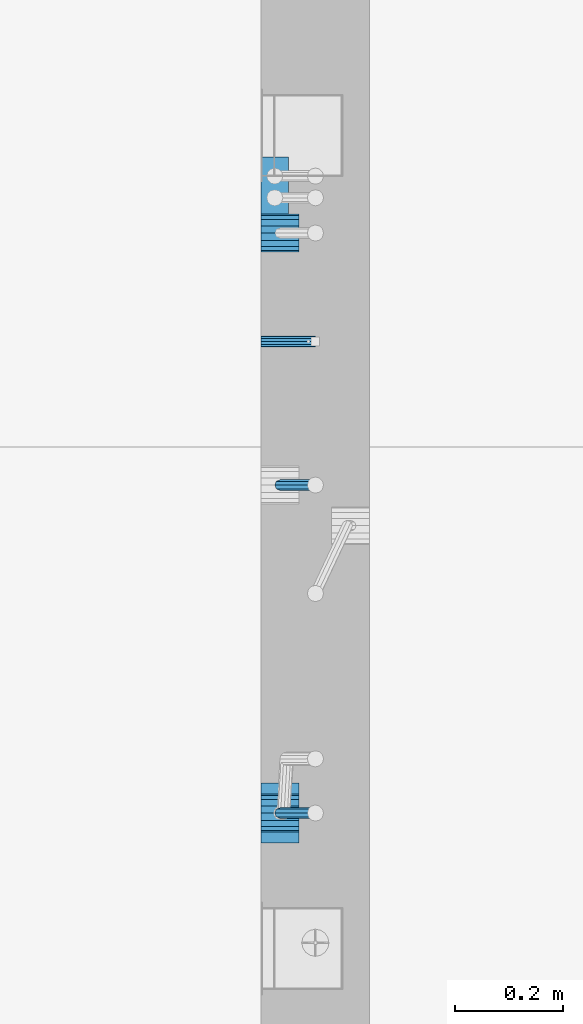
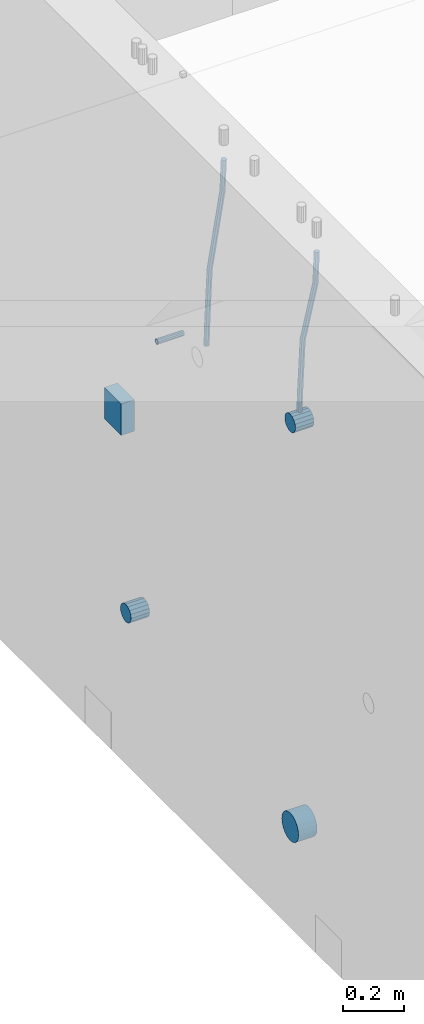
# One storey, part 145 of 350: 7 beams, 2 elements without a shape of their own.
"""IFC2X3 building model written with IfcOpenShell, lengths in millimetres."""

from ifc_helpers import new_model, si_unit, frame, origin_with_axes, place, context, subcontext, project, spatial, faceted_brep, material, type_object, element, aggregate, save


model = new_model("IFC2X3")

# Units and contexts
model_context = context("Model", 3, precision=1e-05, world=origin_with_axes())
body_context = subcontext(model_context, "Body", "Model", "MODEL_VIEW")
ifc_project = project(units=[si_unit("LENGTHUNIT", "METRE", prefix="MILLI"), si_unit("AREAUNIT", "SQUARE_METRE"), si_unit("VOLUMEUNIT", "CUBIC_METRE"), si_unit("MASSUNIT", "GRAM", prefix="KILO"), si_unit("TIMEUNIT", "SECOND"), si_unit("PLANEANGLEUNIT", "RADIAN"), si_unit("SOLIDANGLEUNIT", "STERADIAN"), si_unit("THERMODYNAMICTEMPERATUREUNIT", "DEGREE_CELSIUS"), si_unit("LUMINOUSINTENSITYUNIT", "LUMEN")], contexts=[model_context])

# Site, building, storey
site_placement = place(None, origin_with_axes())
site = spatial("IfcSite", under=ifc_project, at=site_placement, CompositionType="ELEMENT")
building_placement = place(site_placement, origin_with_axes())
building = spatial("IfcBuilding", under=site, at=building_placement, CompositionType="ELEMENT")
storey_placement = place(building_placement, origin_with_axes())
storey = spatial("IfcBuildingStorey", under=building, at=storey_placement, Name="2", CompositionType="ELEMENT", Elevation=0.0)

# Assemblies, beams
assembly_1_placement = place(storey_placement, origin_with_axes())
assembly_1 = element("IfcElementAssembly", 1, at=assembly_1_placement, inside=storey, AssemblyPlace="NOTDEFINED", PredefinedType="REINFORCEMENT_UNIT")
assembly_2_placement = place(assembly_1_placement, origin_with_axes())
assembly_2 = element("IfcElementAssembly", 2, at=assembly_2_placement, Name="Steel Assembly", AssemblyPlace="NOTDEFINED", PredefinedType="RIGID_FRAME")
ifc_material_1 = material(Name="STEEL/Steel_Undefined")
beam_type_1 = type_object("IfcBeamType", PredefinedType="NOTDEFINED")
beam_1_placement = place(assembly_2_placement, frame((21710.0, 11374.9997839591, 86555.0), z_axis=(0.0, 1.0, 0.0), x_axis=(1.0, 0.0, 0.0)))
beam_1 = element("IfcBeam", 3, at=beam_1_placement, type_object=beam_type_1, material=ifc_material_1, Name="M16", context=body_context, shape_type="Brep", body=[
    faceted_brep([(0.0, -8.49999999999272, -1.45519152283669e-11), (0.0, -7.36121593215648, 4.24999999998545), (100.000000000262, -7.36121593215648, 4.24999999998545), (100.000000000262, -8.49999999999272, -1.45519152283669e-11), (0.0, -4.24999999998545, 7.36121593216376), (100.000000000262, -4.24999999998545, 7.36121593216376), (0.0, 1.45519152283669e-11, 8.49999999998545), (100.000000000262, 1.45519152283669e-11, 8.49999999998545), (0.0, 4.25000000001455, 7.36121593216376), (100.000000000262, 4.25000000001455, 7.36121593216376), (0.0, 7.36121593217104, 4.24999999998545), (100.000000000262, 7.36121593217104, 4.24999999998545), (0.0, 8.50000000000728, 0.0), (100.000000000262, 8.50000000000728, 0.0), (0.0, 7.36121593217104, -4.25000000001455), (100.000000000262, 7.36121593217104, -4.25000000001455), (0.0, 4.25000000000728, -7.36121593219286), (100.000000000262, 4.25000000000728, -7.36121593219286), (0.0, 7.27595761418343e-12, -8.5), (100.000000000262, 7.27595761418343e-12, -8.5), (0.0, -4.24999999999272, -7.36121593217831), (100.000000000262, -4.24999999999272, -7.36121593217831), (0.0, -7.36121593215648, -4.25), (100.000000000262, -7.36121593215648, -4.25), (0.0, -10.4999999999927, -1.45519152283669e-11), (0.0, -9.09326673972828, -5.25000000001455), (100.000000000262, -9.09326673972828, -5.25000000001455), (100.000000000262, -10.4999999999927, -1.45519152283669e-11), (0.0, -5.24999999998545, -9.09326673974283), (100.000000000262, -5.24999999998545, -9.09326673974283), (0.0, 7.27595761418343e-12, -10.5), (100.000000000262, 7.27595761418343e-12, -10.5), (0.0, 5.25000000001455, -9.09326673975738), (100.000000000262, 5.25000000001455, -9.09326673975738), (0.0, 9.09326673975011, -5.25000000001455), (100.000000000262, 9.09326673975011, -5.25000000001455), (0.0, 10.5000000000073, -1.45519152283669e-11), (100.000000000262, 10.5000000000073, -1.45519152283669e-11), (0.0, 9.09326673975011, 5.25), (100.000000000262, 9.09326673975011, 5.25), (0.0, 5.25000000000728, 9.09326673972828), (100.000000000262, 5.25000000000728, 9.09326673972828), (0.0, 1.45519152283669e-11, 10.4999999999854), (100.000000000262, 1.45519152283669e-11, 10.4999999999854), (0.0, -5.24999999999272, 9.09326673972828), (100.000000000262, -5.24999999999272, 9.09326673972828), (0.0, -9.09326673972828, 5.24999999998545), (100.000000000262, -9.09326673972828, 5.24999999998545)], [[[0, 1, 2, 3]], [[1, 4, 5, 2]], [[4, 6, 7, 5]], [[6, 8, 9, 7]], [[8, 10, 11, 9]], [[10, 12, 13, 11]], [[12, 14, 15, 13]], [[14, 16, 17, 15]], [[16, 18, 19, 17]], [[18, 20, 21, 19]], [[20, 22, 23, 21]], [[22, 0, 3, 23]], [[24, 25, 26, 27]], [[25, 28, 29, 26]], [[28, 30, 31, 29]], [[30, 32, 33, 31]], [[32, 34, 35, 33]], [[34, 36, 37, 35]], [[36, 38, 39, 37]], [[38, 40, 41, 39]], [[40, 42, 43, 41]], [[42, 44, 45, 43]], [[44, 46, 47, 45]], [[46, 24, 27, 47]], [[29, 31, 33, 35, 37, 39, 41, 43, 45, 47, 27, 26], [5, 7, 9, 11, 13, 15, 17, 19, 21, 23, 3, 2]], [[46, 44, 42, 40, 38, 36, 34, 32, 30, 28, 25, 24], [22, 20, 18, 16, 14, 12, 10, 8, 6, 4, 1, 0]]]),
])
aggregate(assembly_2, [beam_1])
ifc_material_2 = material()
beam_type_2 = type_object("IfcBeamType", Name="D20", PredefinedType="NOTDEFINED")
beam_2_placement = place(assembly_1_placement, frame((21744.9999977209, 10504.9999999961, 86795.0), z_axis=(0.999642804629538, 0.000205762999925497, -0.0267249099901003), x_axis=(0.0267249109941254, -4.30000210532798e-08, 0.999642825779465)))
beam_2 = element("IfcBeam", 4, at=beam_2_placement, type_object=beam_type_2, material=ifc_material_2, Name="JM20", ObjectType="D20", context=body_context, shape_type="Brep", body=[
    faceted_brep([(0.0, -10.0, 0.0), (-4.19531716033816e-08, -7.07106781186667, -7.07106781187031), (60.3902110151248, -7.07106779622882, -7.07106780570393), (60.3902110191848, -9.99999998436397, 6.15546014159918e-09), (0.0, 0.0, -10.0), (60.3902110119234, 1.56360329128802e-08, -9.99999999383726), (4.196772351861e-08, 7.07106781186303, -7.07106781186667), (60.3902110114723, 7.07106782750088, -7.07106780570757), (0.0, 10.0, 0.0), (60.3902110140189, 10.000000015636, 6.15909812040627e-09), (4.196772351861e-08, 7.07106781185939, 7.07106781185939), (60.3902110180788, 7.07106782750088, 7.07106781802213), (0.0, 0.0, 10.0), (60.3902110212803, 1.56378519022837e-08, 10.0000000061627), (-4.19531716033816e-08, -7.07106781187031, 7.07106781185939), (60.3902110217459, -7.07106779622882, 7.07106781802213), (61.0636251037213, -7.07106779605601, -7.07106780563481), (60.991799419251, -9.99999998403655, 6.21366780251265e-09), (61.0933608038758, 1.58179318532348e-08, -9.99999999376814), (61.0635953103047, 7.07106782767551, -7.07106780563481), (60.9917724058905, 10.0000000159635, 6.21366780251265e-09), (60.9199467214348, 7.07106782763913, 7.07106781808034), (60.8902110212803, 1.57651811605319e-08, 10.0000000062137), (60.919976514866, -7.07106779609421, 7.07106781808034), (61.736900248201, -7.07106495914195, -7.05738882369405), (61.5932788141945, -9.99999744984598, 0.0122201548947487), (61.7963655163912, 2.97800033877138e-06, -9.98571699394597), (61.7368406711612, 7.07107066446406, -7.05738942880998), (61.5931945595512, 10.0000025499758, 0.0122192991293559), (61.4495731255302, 7.07107005927173, 7.0818282777218), (61.3901078573399, 2.12213126360439e-06, 10.0101564479701), (61.4496327025554, -7.07106556433428, 7.08182888283409), (278.724613209561, -7.07015065944142, -2.64883307638229), (278.580991775569, -9.99908315014545, 4.42077590220288), (278.78407847778, 0.000917277700864361, -5.57716124663784), (278.724553632535, 7.07198496416277, -2.64883368149822), (278.580907520925, 10.0009168496781, 4.42077504644112), (278.437286086933, 7.07198435897226, 11.4903840250299), (278.377820818714, 0.000916421833608183, 14.4187121952782), (278.437345663944, -7.07015126463193, 11.4903846301422), (280.757740145142, -7.07014209265617, -2.60752588292962), (279.97914288567, -9.99907725889352, 4.4491822438722), (281.080112136013, 0.000926952270674519, -5.53051255744504), (280.757417718196, 7.07199352984026, -2.60753182838744), (279.978686905117, 10.0009227393621, 4.44917383572465), (279.200089645645, 7.0719875731229, 11.5058819625192), (278.877717654759, 0.000918528197871638, 14.4288686370419), (279.200412072576, -7.07014804937353, 11.5058879079807), (282.750959243713, -7.07005867588668, -2.20455064874841), (281.349849970706, -9.99901989442333, 4.72630231008952), (283.331077414448, 0.00102115578738449, -5.07542798552822), (282.750379126286, 7.07207693582313, -2.20460869228191), (281.349029560777, 10.0009800885819, 4.72622022413998), (279.947920287756, 7.07201887003976, 11.6570731829706), (279.367802117034, 0.000939038367505418, 14.5279505197614), (279.948500405197, -7.07011674167188, 11.6571312265078), (490.42756900216, -7.06136735270411, 39.782068138702), (489.026459729153, -9.99032857123893, 46.7129210975436), (491.007687172896, 0.00971247897177818, 36.9111908019222), (490.426988884734, 7.08076825901298, 39.7820100951685), (489.02563931921, 10.0096714117662, 46.7128390115868), (487.624530046218, 7.08071019322961, 53.6436919704247), (487.044411875468, 0.0096303615537181, 56.5145693072081), (487.625110163644, -7.06142541848567, 53.6437500139618), (491.139936791646, -7.06133753991526, 39.9260897251916), (490.366909417033, -9.99027247305094, 46.9839239327412), (491.497771635157, 0.00973298914141196, 37.0102726846344), (491.230799149358, 7.08080189869361, 39.9445188880345), (490.495408195638, 10.0097329219989, 47.0099867047757), (489.722380821026, 7.08079798886138, 54.0678209123216), (489.3645459775, 0.00972745980288892, 56.9836379528824), (489.631518463313, -7.06134144974749, 54.0493917494787), (491.866591294849, -7.07081326331172, 39.9357607788479), (491.734242157807, -10.008102771757, 47.0021217808862), (491.997684863585, 0.00321401835935831, 37.0169260358998), (492.050730029368, 7.07010983225518, 39.955431358132), (491.994653653514, 9.99018245447223, 47.0299401808879), (491.862304516457, 7.05289294603062, 54.0963011829335), (491.731210947721, -0.0211343356422731, 57.0151359258853), (491.678165781937, -7.08803014953628, 54.0766306036494), (512.839658019177, -7.34430634461387, 40.2148915801045), (512.707308882134, -10.2815958530537, 47.2812525821391), (512.970751587927, -0.270279062942791, 37.2960568371527), (513.023796753681, 6.79661675095485, 40.2345621593813), (512.967720377841, 9.7166893731719, 47.3090709821408), (512.835371240784, 6.77939986473211, 54.3754319841792), (512.704277672048, -0.294627416940784, 57.2942667271309), (512.651232506279, -7.36152323083843, 54.3557614048987), (513.475023168634, -7.35259163615956, 40.2233476626352), (513.367394028246, -10.2902034984181, 47.2900376634097), (513.548964110931, -0.277819072547572, 37.3037522746854), (513.54590325398, 6.78980837536619, 40.2415108811765), (513.467633606255, 9.71017040238803, 47.3157243334063), (513.360004465882, 6.77255854013129, 54.3824143341844), (513.28606352357, -0.302214023480701, 57.3020097221342), (513.289124380535, -7.36984147139265, 54.3642511156468), (514.110442121717, -7.35071708105352, 40.2316099536038), (514.027534909808, -10.2882349910469, 47.298629034136), (514.127225867254, -0.276123320652914, 37.311252921696), (514.068054455944, 6.79134521359629, 40.248263480742), (513.967589697961, 9.71166130597521, 47.3221806780894), (513.884682486052, 6.77414339598363, 54.3891997586288), (513.8678987405, -0.300450364420612, 57.309556790533), (513.927070151825, -7.36791889866981, 54.3725462314869), (614.131230002764, -7.05245493793518, 41.5289880054152), (614.048322790841, -9.98997284792858, 48.596007085951), (614.148013748316, 0.022138822467241, 38.608630973511), (614.088842336976, 7.08960735671644, 41.5456415325607), (613.988377579022, 10.0099234490935, 48.6195587299044), (613.905470367114, 7.07240553910196, 55.6865778104475), (613.888686621562, -0.00218822130045737, 58.6069348423516), (613.947858032887, -7.06965675554966, 55.6699242832983)], [[[0, 1, 2, 3]], [[1, 4, 5, 2]], [[4, 6, 7, 5]], [[6, 8, 9, 7]], [[8, 10, 11, 9]], [[10, 12, 13, 11]], [[12, 14, 15, 13]], [[14, 0, 3, 15]], [[14, 12, 10, 8, 6, 4, 1, 0]], [[3, 2, 16, 17]], [[2, 5, 18, 16]], [[5, 7, 19, 18]], [[7, 9, 20, 19]], [[9, 11, 21, 20]], [[11, 13, 22, 21]], [[13, 15, 23, 22]], [[15, 3, 17, 23]], [[17, 16, 24, 25]], [[16, 18, 26, 24]], [[18, 19, 27, 26]], [[19, 20, 28, 27]], [[20, 21, 29, 28]], [[21, 22, 30, 29]], [[22, 23, 31, 30]], [[23, 17, 25, 31]], [[25, 24, 32, 33]], [[24, 26, 34, 32]], [[26, 27, 35, 34]], [[27, 28, 36, 35]], [[28, 29, 37, 36]], [[29, 30, 38, 37]], [[30, 31, 39, 38]], [[31, 25, 33, 39]], [[33, 32, 40, 41]], [[32, 34, 42, 40]], [[34, 35, 43, 42]], [[35, 36, 44, 43]], [[36, 37, 45, 44]], [[37, 38, 46, 45]], [[38, 39, 47, 46]], [[39, 33, 41, 47]], [[41, 40, 48, 49]], [[40, 42, 50, 48]], [[42, 43, 51, 50]], [[43, 44, 52, 51]], [[44, 45, 53, 52]], [[45, 46, 54, 53]], [[46, 47, 55, 54]], [[47, 41, 49, 55]], [[49, 48, 56, 57]], [[48, 50, 58, 56]], [[50, 51, 59, 58]], [[51, 52, 60, 59]], [[52, 53, 61, 60]], [[53, 54, 62, 61]], [[54, 55, 63, 62]], [[55, 49, 57, 63]], [[57, 56, 64, 65]], [[56, 58, 66, 64]], [[58, 59, 67, 66]], [[59, 60, 68, 67]], [[60, 61, 69, 68]], [[61, 62, 70, 69]], [[62, 63, 71, 70]], [[63, 57, 65, 71]], [[65, 64, 72, 73]], [[64, 66, 74, 72]], [[66, 67, 75, 74]], [[67, 68, 76, 75]], [[68, 69, 77, 76]], [[69, 70, 78, 77]], [[70, 71, 79, 78]], [[71, 65, 73, 79]], [[73, 72, 80, 81]], [[72, 74, 82, 80]], [[74, 75, 83, 82]], [[75, 76, 84, 83]], [[76, 77, 85, 84]], [[77, 78, 86, 85]], [[78, 79, 87, 86]], [[79, 73, 81, 87]], [[81, 80, 88, 89]], [[80, 82, 90, 88]], [[82, 83, 91, 90]], [[83, 84, 92, 91]], [[84, 85, 93, 92]], [[85, 86, 94, 93]], [[86, 87, 95, 94]], [[87, 81, 89, 95]], [[89, 88, 96, 97]], [[88, 90, 98, 96]], [[90, 91, 99, 98]], [[91, 92, 100, 99]], [[92, 93, 101, 100]], [[93, 94, 102, 101]], [[94, 95, 103, 102]], [[95, 89, 97, 103]], [[97, 96, 104, 105]], [[96, 98, 106, 104]], [[98, 99, 107, 106]], [[99, 100, 108, 107]], [[100, 101, 109, 108]], [[101, 102, 110, 109]], [[102, 103, 111, 110]], [[103, 97, 105, 111]], [[106, 107, 108, 109, 110, 111, 105, 104]]]),
])
beam_3_placement = place(assembly_1_placement, frame((21744.9999977209, 11109.9999999961, 86690.0), z_axis=(0.999642804629538, 0.000205762999925497, -0.0267249099901003), x_axis=(0.0267249109941254, -4.30000210532798e-08, 0.999642825779465)))
beam_3 = element("IfcBeam", 5, at=beam_3_placement, type_object=beam_type_2, material=ifc_material_2, Name="JM20", ObjectType="D20", context=body_context, shape_type="Brep", body=[
    faceted_brep([(0.0, -10.0, 0.0), (-4.19531716033816e-08, -7.07106781186667, -7.07106781187031), (60.4266690400545, -7.0710677960451, -7.07106780570757), (60.4266690441291, -9.99999998418934, 6.15546014159918e-09), (0.0, 0.0, -10.0), (60.426669036824, 1.58106558956206e-08, -9.99999999384454), (4.196772351861e-08, 7.07106781186303, -7.07106781186667), (60.4266690363438, 7.07106782768096, -7.07106780570757), (0.0, 10.0, 0.0), (60.4266690388904, 10.0000000158179, 6.15182216279209e-09), (4.196772351861e-08, 7.07106781185939, 7.07106781185939), (60.4266690429649, 7.07106782768096, 7.07106781802577), (0.0, 0.0, 10.0), (60.4266690461809, 1.58179318532348e-08, 10.0000000061555), (-4.19531716033816e-08, -7.07106781187031, 7.07106781185939), (60.4266690466611, -7.07106779605238, 7.07106781802213), (61.0378400410118, -7.07106779588503, -7.07106780564936), (60.991799419251, -9.99999998403655, 6.21366780251265e-09), (61.0569027789461, 1.5985278878361e-08, -9.99999999378269), (61.0378209396877, 7.07106782784831, -7.07106780564936), (60.9917724058905, 10.0000000159635, 6.21366780251265e-09), (60.9457317841297, 7.07106782781193, 7.0710678180767), (60.9266690461809, 1.59488990902901e-08, 10.0000000062028), (60.9457508854539, -7.07106779591413, 7.0710678180767), (61.6489592143771, -7.07106614513759, -7.06310863441468), (61.5568818710308, -9.9999984576425, 0.00735959856683621), (61.6870830769039, 1.71821739058942e-06, -9.99179257185824), (61.6489210170112, 7.07106947854481, -7.06310888312146), (61.556827851804, 10.0000015422847, 0.00735924683976918), (61.4647505084577, 7.07106922979438, 7.07782747982128), (61.4266266459163, 1.36643211590126e-06, 10.0065114172685), (61.464788705809, -7.07106639389531, 7.07782772852806), (176.543135720174, -7.07075579406956, -5.56673531796696), (176.451058376813, -9.99968810657447, 1.50373291501455), (176.581259582701, 0.000312069292704109, -8.49541925541052), (176.543097522794, 7.07137982961285, -5.56673556667374), (176.451004357587, 10.00031189336, 1.50373256329476), (176.35892701424, 7.07137958085514, 8.57420079627263), (176.320803151699, 0.000311717507429421, 11.5028847337162), (176.358965211621, -7.07075604281999, 8.57420104497578), (177.098753836006, -7.07075429323595, -5.55949898843028), (176.98362511232, -9.99968666800123, 1.510669025065), (177.146421932586, 0.000313595905026887, -8.48805862247536), (177.098706077581, 7.07138133041735, -5.55949936166144), (176.983557571715, 10.0003133318824, 1.51066849724157), (176.868428848029, 7.07138095712435, 8.58083651073321), (176.820760751449, 0.000313067976094317, 11.5093961447819), (176.868476606425, -7.07075466652896, 8.58083688396073), (177.654312950661, -7.07075204110879, -5.54863964998367), (177.516135294456, -9.99968450931192, 1.52107783331303), (177.711524267797, 0.000315886711177882, -8.47701274570863), (177.654255632195, 7.07138358250813, -5.54864021007961), (177.516054233929, 10.0003154905207, 1.5210770412159), (177.377876577739, 7.0713830223176, 8.59079452451624), (177.320665260588, 0.000315094497636892, 11.5191676202448), (177.377933896176, -7.07075260129932, 8.59079508461218), (299.029771459231, -7.07026000924998, -3.17615191846562), (298.89159380304, -9.99919247745311, 3.89356556482744), (299.086982776382, 0.00080791857362783, -6.10452501419059), (299.029714140794, 7.07187561436331, -3.1761524785652), (298.891512742513, 10.0008075223832, 3.89356477273031), (298.753335086294, 7.07187505418005, 10.963282256027), (298.696123769172, 0.000807126352810883, 13.891655351752), (298.75339240476, -7.07026056943323, 10.963282816123), (300.5204182054, -7.07025396646532, -3.14701471758235), (299.971932015731, -9.99918809797782, 3.91468259446992), (300.747514543924, 0.000814650038591935, -6.07206712448169), (300.520191076153, 7.07188165646039, -3.14701859691559), (299.971610806504, 10.0008119008835, 3.91467710826691), (299.423124616849, 7.0718777693728, 10.9763744203192), (299.196028278326, 0.000809152865258511, 13.9014268272185), (299.423351746067, -7.0702578535529, 10.9763782996524), (301.997683885507, -7.07021227996847, -2.94561261413764), (301.042572372782, -9.99915788591352, 4.06064768581928), (302.393140241125, 0.000861087435623631, -5.84771176216236), (301.997288469822, 7.07192333820967, -2.94563943669345), (301.042013170576, 10.0008421062339, 4.0606097529926), (300.086901657865, 7.07189650029068, 11.0668700529459), (299.691445302247, 0.000823132886580424, 13.9689692009706), (300.087297073522, -7.07023911788747, 11.066896875509), (595.247547294217, -7.06193715364316, 37.0344262651415), (594.292435781506, -9.99088275958638, 44.0406865650948), (595.643003649835, 0.00913621376093943, 34.1323271171168), (595.247151878561, 7.08019846453499, 37.0343994425784), (594.291876579315, 10.0091172325574, 44.0406486322681), (593.336765066575, 7.08017162661235, 51.0469089322251), (592.941308710972, 0.00909825921189622, 53.9490080802498), (593.337160482261, -7.06196399156397, 51.0469357547881), (595.874536898147, -7.0619194608189, 37.1199065052715), (595.328959329563, -9.99085351025315, 44.1820003623798), (596.138420673757, 0.00915019377680437, 34.1998694908689), (595.966031119533, 7.08021875036138, 37.132407399582), (595.458351698282, 10.0091501489569, 44.1996792966529), (594.912774129698, 7.08021609952084, 51.2617731537612), (594.648890354089, 0.00914644492513617, 54.1818101681638), (594.821279908327, -7.06192211166126, 51.2492722594543), (596.507216806087, -7.07016973634745, 37.1283268498955), (596.374889946004, -10.0044926596274, 44.1959206657302), (596.638333902185, 0.00263122293472406, 34.2065228421343), (596.691434617649, 7.07075934023669, 37.1420618035991), (596.635413273558, 9.99380102503346, 44.2153448235404), (596.503086413475, 7.05947810175894, 51.2829386393751), (596.371969317406, -0.0133228575232351, 54.2047426471363), (596.318868601928, -7.08145097482702, 51.2692036856752), (617.802075790198, -7.34785905717763, 37.4117403882592), (617.669748930144, -10.282181980454, 44.4793342040939), (617.933192886281, -0.275058097895453, 34.4899363805016), (617.98629360176, 6.79307001940651, 37.4254753419664), (617.930272257669, 9.7161117042051, 44.498758361904), (617.797945397615, 6.78178878092876, 51.5663521777387), (617.666828301532, -0.291012178353412, 54.4881561855073), (617.613727586038, -7.35914029565538, 51.5526172240352), (618.437465979412, -7.3561446753265, 37.4201968040506), (618.329835563593, -10.2907896452944, 44.488119305166), (618.51143976918, -0.28259855563374, 34.4976322753282), (618.508424090105, 6.78626133094076, 37.4324243830088), (618.430185486082, 9.70959273336121, 44.5054117131695), (618.322555070263, 6.77494776339336, 51.5733342142812), (618.248581280495, -0.298598356299408, 54.4958987430036), (618.25159695957, -7.36745824287755, 51.5611066353231), (619.072909978044, -7.35426965608167, 37.428459048002), (618.989977939549, -10.2888211210229, 44.4967101569127), (619.089735886533, -0.2809021629364, 34.5051333804877), (619.030599275982, 6.78779861257681, 37.4391776831617), (618.930141570861, 9.7110836245156, 44.5118685961243), (618.847209532338, 6.77653215957434, 51.5801197050387), (618.830383623877, -0.296835333569106, 54.503445372553), (618.889520234414, -7.36553610908049, 51.569401069879), (719.093697115357, -7.05600751202655, 38.7258370901727), (719.010765076877, -9.9905589769678, 45.7940881990799), (719.110523023846, 0.017359981116897, 35.8025114226548), (719.051386413325, 7.08606075662829, 38.7365557253288), (718.950928708175, 10.0093457685707, 45.809246638295), (718.86799666968, 7.07479430362946, 52.8774977472058), (718.851170761191, 0.00142681048419036, 55.8008234147201), (718.910307371727, -7.06727396502902, 52.8667791120424)], [[[0, 1, 2, 3]], [[1, 4, 5, 2]], [[4, 6, 7, 5]], [[6, 8, 9, 7]], [[8, 10, 11, 9]], [[10, 12, 13, 11]], [[12, 14, 15, 13]], [[14, 0, 3, 15]], [[14, 12, 10, 8, 6, 4, 1, 0]], [[3, 2, 16, 17]], [[2, 5, 18, 16]], [[5, 7, 19, 18]], [[7, 9, 20, 19]], [[9, 11, 21, 20]], [[11, 13, 22, 21]], [[13, 15, 23, 22]], [[15, 3, 17, 23]], [[17, 16, 24, 25]], [[16, 18, 26, 24]], [[18, 19, 27, 26]], [[19, 20, 28, 27]], [[20, 21, 29, 28]], [[21, 22, 30, 29]], [[22, 23, 31, 30]], [[23, 17, 25, 31]], [[25, 24, 32, 33]], [[24, 26, 34, 32]], [[26, 27, 35, 34]], [[27, 28, 36, 35]], [[28, 29, 37, 36]], [[29, 30, 38, 37]], [[30, 31, 39, 38]], [[31, 25, 33, 39]], [[33, 32, 40, 41]], [[32, 34, 42, 40]], [[34, 35, 43, 42]], [[35, 36, 44, 43]], [[36, 37, 45, 44]], [[37, 38, 46, 45]], [[38, 39, 47, 46]], [[39, 33, 41, 47]], [[41, 40, 48, 49]], [[40, 42, 50, 48]], [[42, 43, 51, 50]], [[43, 44, 52, 51]], [[44, 45, 53, 52]], [[45, 46, 54, 53]], [[46, 47, 55, 54]], [[47, 41, 49, 55]], [[49, 48, 56, 57]], [[48, 50, 58, 56]], [[50, 51, 59, 58]], [[51, 52, 60, 59]], [[52, 53, 61, 60]], [[53, 54, 62, 61]], [[54, 55, 63, 62]], [[55, 49, 57, 63]], [[57, 56, 64, 65]], [[56, 58, 66, 64]], [[58, 59, 67, 66]], [[59, 60, 68, 67]], [[60, 61, 69, 68]], [[61, 62, 70, 69]], [[62, 63, 71, 70]], [[63, 57, 65, 71]], [[65, 64, 72, 73]], [[64, 66, 74, 72]], [[66, 67, 75, 74]], [[67, 68, 76, 75]], [[68, 69, 77, 76]], [[69, 70, 78, 77]], [[70, 71, 79, 78]], [[71, 65, 73, 79]], [[73, 72, 80, 81]], [[72, 74, 82, 80]], [[74, 75, 83, 82]], [[75, 76, 84, 83]], [[76, 77, 85, 84]], [[77, 78, 86, 85]], [[78, 79, 87, 86]], [[79, 73, 81, 87]], [[81, 80, 88, 89]], [[80, 82, 90, 88]], [[82, 83, 91, 90]], [[83, 84, 92, 91]], [[84, 85, 93, 92]], [[85, 86, 94, 93]], [[86, 87, 95, 94]], [[87, 81, 89, 95]], [[89, 88, 96, 97]], [[88, 90, 98, 96]], [[90, 91, 99, 98]], [[91, 92, 100, 99]], [[92, 93, 101, 100]], [[93, 94, 102, 101]], [[94, 95, 103, 102]], [[95, 89, 97, 103]], [[97, 96, 104, 105]], [[96, 98, 106, 104]], [[98, 99, 107, 106]], [[99, 100, 108, 107]], [[100, 101, 109, 108]], [[101, 102, 110, 109]], [[102, 103, 111, 110]], [[103, 97, 105, 111]], [[105, 104, 112, 113]], [[104, 106, 114, 112]], [[106, 107, 115, 114]], [[107, 108, 116, 115]], [[108, 109, 117, 116]], [[109, 110, 118, 117]], [[110, 111, 119, 118]], [[111, 105, 113, 119]], [[113, 112, 120, 121]], [[112, 114, 122, 120]], [[114, 115, 123, 122]], [[115, 116, 124, 123]], [[116, 117, 125, 124]], [[117, 118, 126, 125]], [[118, 119, 127, 126]], [[119, 113, 121, 127]], [[121, 120, 128, 129]], [[120, 122, 130, 128]], [[122, 123, 131, 130]], [[123, 124, 132, 131]], [[124, 125, 133, 132]], [[125, 126, 134, 133]], [[126, 127, 135, 134]], [[127, 121, 129, 135]], [[130, 131, 132, 133, 134, 135, 129, 128]]]),
])
beam_type_3 = type_object("IfcBeamType", Name="D70", PredefinedType="NOTDEFINED")
beam_4_placement = place(assembly_1_placement, frame((21709.9999977209, 10505.0, 86760.0), z_axis=(0.0, 0.0, 1.0), x_axis=(1.0, 0.0, 0.0)))
beam_4 = element("IfcBeam", 6, at=beam_4_placement, type_object=beam_type_3, material=ifc_material_2, ObjectType="D70", context=body_context, shape_type="Brep", body=[
    faceted_brep([(0.0, -35.0, 0.0), (0.0, -32.3357836378964, -13.3939201327739), (70.0, -32.3357836378964, -13.3939201327739), (70.0, -35.0, 0.0), (0.0, -24.7487373415279, -24.7487373415352), (70.0, -24.7487373415279, -24.7487373415352), (0.0, -13.3939201327776, -32.3357836379), (70.0, -13.3939201327776, -32.3357836379), (0.0, 0.0, -35.0), (70.0, 0.0, -35.0), (0.0, 13.3939201327776, -32.3357836379), (70.0, 13.3939201327776, -32.3357836379), (0.0, 24.7487373415279, -24.7487373415352), (70.0, 24.7487373415279, -24.7487373415352), (0.0, 32.3357836378964, -13.3939201327739), (70.0, 32.3357836378964, -13.3939201327739), (0.0, 35.0, 0.0), (70.0, 35.0, 0.0), (0.0, 32.3357836378964, 13.3939201327739), (70.0, 32.3357836378964, 13.3939201327739), (0.0, 24.7487373415279, 24.7487373415352), (70.0, 24.7487373415279, 24.7487373415352), (0.0, 13.3939201327776, 32.3357836379), (70.0, 13.3939201327776, 32.3357836379), (0.0, 0.0, 35.0), (70.0, 0.0, 35.0), (0.0, -13.3939201327776, 32.3357836379), (70.0, -13.3939201327776, 32.3357836379), (0.0, -24.7487373415279, 24.7487373415352), (70.0, -24.7487373415279, 24.7487373415352), (0.0, -32.3357836378964, 13.3939201327739), (70.0, -32.3357836378964, 13.3939201327739)], [[[0, 1, 2, 3]], [[1, 4, 5, 2]], [[4, 6, 7, 5]], [[6, 8, 9, 7]], [[8, 10, 11, 9]], [[10, 12, 13, 11]], [[12, 14, 15, 13]], [[14, 16, 17, 15]], [[16, 18, 19, 17]], [[18, 20, 21, 19]], [[20, 22, 23, 21]], [[22, 24, 25, 23]], [[24, 26, 27, 25]], [[26, 28, 29, 27]], [[28, 30, 31, 29]], [[30, 0, 3, 31]], [[5, 7, 9, 11, 13, 15, 17, 19, 21, 23, 25, 27, 29, 31, 3, 2]], [[30, 28, 26, 24, 22, 20, 18, 16, 14, 12, 10, 8, 6, 4, 1, 0]]]),
])
beam_5_placement = place(assembly_1_placement, frame((21709.9999977209, 11575.0, 85355.0), z_axis=(0.0, 0.0, 1.0), x_axis=(1.0, 0.0, 0.0)))
beam_5 = element("IfcBeam", 7, at=beam_5_placement, type_object=beam_type_3, material=ifc_material_2, ObjectType="D70", context=body_context, shape_type="Brep", body=[
    faceted_brep([(0.0, -35.0, 0.0), (0.0, -32.3357836378964, -13.3939201327739), (70.0, -32.3357836378964, -13.3939201327739), (70.0, -35.0, 0.0), (0.0, -24.7487373415279, -24.7487373415352), (70.0, -24.7487373415279, -24.7487373415352), (0.0, -13.3939201327776, -32.3357836379), (70.0, -13.3939201327776, -32.3357836379), (0.0, 0.0, -35.0), (70.0, 0.0, -35.0), (0.0, 13.3939201327776, -32.3357836379), (70.0, 13.3939201327776, -32.3357836379), (0.0, 24.7487373415279, -24.7487373415352), (70.0, 24.7487373415279, -24.7487373415352), (0.0, 32.3357836378964, -13.3939201327739), (70.0, 32.3357836378964, -13.3939201327739), (0.0, 35.0, 0.0), (70.0, 35.0, 0.0), (0.0, 32.3357836378964, 13.3939201327739), (70.0, 32.3357836378964, 13.3939201327739), (0.0, 24.7487373415279, 24.7487373415352), (70.0, 24.7487373415279, 24.7487373415352), (0.0, 13.3939201327776, 32.3357836379), (70.0, 13.3939201327776, 32.3357836379), (0.0, 0.0, 35.0), (70.0, 0.0, 35.0), (0.0, -13.3939201327776, 32.3357836379), (70.0, -13.3939201327776, 32.3357836379), (0.0, -24.7487373415279, 24.7487373415352), (70.0, -24.7487373415279, 24.7487373415352), (0.0, -32.3357836378964, 13.3939201327739), (70.0, -32.3357836378964, 13.3939201327739)], [[[0, 1, 2, 3]], [[1, 4, 5, 2]], [[4, 6, 7, 5]], [[6, 8, 9, 7]], [[8, 10, 11, 9]], [[10, 12, 13, 11]], [[12, 14, 15, 13]], [[14, 16, 17, 15]], [[16, 18, 19, 17]], [[18, 20, 21, 19]], [[20, 22, 23, 21]], [[22, 24, 25, 23]], [[24, 26, 27, 25]], [[26, 28, 29, 27]], [[28, 30, 31, 29]], [[30, 0, 3, 31]], [[5, 7, 9, 11, 13, 15, 17, 19, 21, 23, 25, 27, 29, 31, 3, 2]], [[30, 28, 26, 24, 22, 20, 18, 16, 14, 12, 10, 8, 6, 4, 1, 0]]]),
])
beam_type_4 = type_object("IfcBeamType", Name="D110", PredefinedType="NOTDEFINED")
beam_6_placement = place(assembly_1_placement, frame((21709.9999977209, 10505.0, 85155.0), z_axis=(0.0, 0.0, 1.0), x_axis=(1.0, 0.0, 0.0)))
beam_6 = element("IfcBeam", 8, at=beam_6_placement, type_object=beam_type_4, material=ifc_material_2, ObjectType="D110", context=body_context, shape_type="Brep", body=[
    faceted_brep([(0.0, -55.0, 0.0), (0.0, -52.3081083962352, -16.9959346906253), (70.0, -52.3081083962352, -16.9959346906253), (70.0, -55.0, 0.0), (0.0, -44.4959346906217, -32.328188876083), (70.0, -44.4959346906217, -32.328188876083), (0.0, -32.3281888760866, -44.4959346906253), (70.0, -32.3281888760866, -44.4959346906253), (0.0, -16.9959346906217, -52.3081083962315), (70.0, -16.9959346906217, -52.3081083962315), (0.0, 0.0, -55.0), (70.0, 0.0, -55.0), (0.0, 16.9959346906217, -52.3081083962315), (70.0, 16.9959346906217, -52.3081083962315), (0.0, 32.3281888760866, -44.4959346906253), (70.0, 32.3281888760866, -44.4959346906253), (0.0, 44.4959346906217, -32.328188876083), (70.0, 44.4959346906217, -32.328188876083), (0.0, 52.3081083962352, -16.9959346906253), (70.0, 52.3081083962352, -16.9959346906253), (0.0, 55.0, 0.0), (70.0, 55.0, 0.0), (0.0, 52.3081083962352, 16.9959346906253), (70.0, 52.3081083962352, 16.9959346906253), (0.0, 44.4959346906217, 32.328188876083), (70.0, 44.4959346906217, 32.328188876083), (0.0, 32.3281888760866, 44.4959346906253), (70.0, 32.3281888760866, 44.4959346906253), (0.0, 16.9959346906217, 52.3081083962315), (70.0, 16.9959346906217, 52.3081083962315), (0.0, 0.0, 55.0), (70.0, 0.0, 55.0), (0.0, -16.9959346906217, 52.3081083962315), (70.0, -16.9959346906217, 52.3081083962315), (0.0, -32.3281888760866, 44.4959346906253), (70.0, -32.3281888760866, 44.4959346906253), (0.0, -44.4959346906217, 32.328188876083), (70.0, -44.4959346906217, 32.328188876083), (0.0, -52.3081083962352, 16.9959346906253), (70.0, -52.3081083962352, 16.9959346906253)], [[[0, 1, 2, 3]], [[1, 4, 5, 2]], [[4, 6, 7, 5]], [[6, 8, 9, 7]], [[8, 10, 11, 9]], [[10, 12, 13, 11]], [[12, 14, 15, 13]], [[14, 16, 17, 15]], [[16, 18, 19, 17]], [[18, 20, 21, 19]], [[20, 22, 23, 21]], [[22, 24, 25, 23]], [[24, 26, 27, 25]], [[26, 28, 29, 27]], [[28, 30, 31, 29]], [[30, 32, 33, 31]], [[32, 34, 35, 33]], [[34, 36, 37, 35]], [[36, 38, 39, 37]], [[38, 0, 3, 39]], [[5, 7, 9, 11, 13, 15, 17, 19, 21, 23, 25, 27, 29, 31, 33, 35, 37, 39, 3, 2]], [[38, 36, 34, 32, 30, 28, 26, 24, 22, 20, 18, 16, 14, 12, 10, 8, 6, 4, 1, 0]]]),
])
beam_type_5 = type_object("IfcBeamType", Name="125X50", PredefinedType="NOTDEFINED")
beam_7_placement = place(assembly_1_placement, frame((21735.0, 11715.0, 86105.0), z_axis=(0.0, 0.0, 1.0), x_axis=(0.0, -1.0, 0.0)))
beam_7 = element("IfcBeam", 9, at=beam_7_placement, type_object=beam_type_5, material=ifc_material_2, Name="WM2", ObjectType="125X50", context=body_context, shape_type="Brep", body=[
    faceted_brep([(0.0, 25.0, -62.5), (0.0, 25.0, 62.5), (110.0, 25.0, 62.5), (110.0, 25.0, -62.5), (0.0, -25.0, 62.5), (110.0, -25.0, 62.5), (0.0, -25.0, -62.5), (110.0, -25.0, -62.5)], [[[0, 1, 2, 3]], [[1, 4, 5, 2]], [[4, 6, 7, 5]], [[6, 0, 3, 7]], [[5, 7, 3, 2]], [[0, 6, 4, 1]]]),
])
aggregate(assembly_1, [beam_2, beam_4, assembly_2, beam_7, beam_5, beam_3, beam_6])

save(model, "model.ifc")
